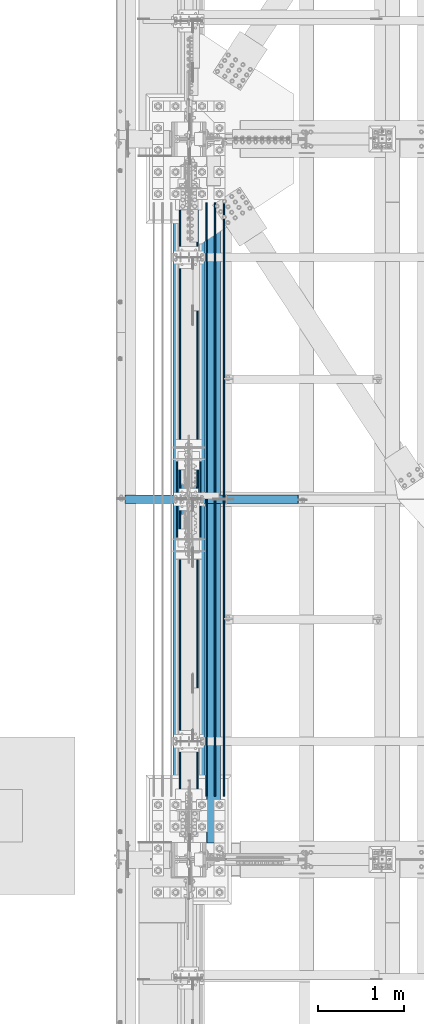
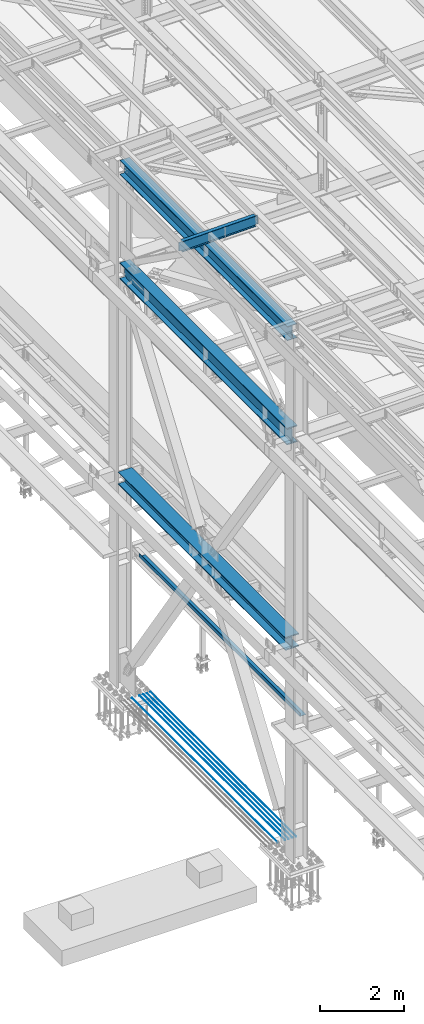
# One storey, part 1813 of 3843: 10 beams, 10 elements without a shape of their own.
"""IFC2X3 building model written with IfcOpenShell, lengths in millimetres."""

from ifc_helpers import new_model, si_unit, frame, origin_with_axes, place, context, subcontext, project, spatial, faceted_brep, material, type_object, element, aggregate, save


model = new_model("IFC2X3")

# Units and contexts
model_context = context("Model", 3, precision=1e-05, world=origin_with_axes())
body_context = subcontext(model_context, "Body", "Model", "MODEL_VIEW")
ifc_project = project(units=[si_unit("LENGTHUNIT", "METRE", prefix="MILLI"), si_unit("AREAUNIT", "SQUARE_METRE"), si_unit("VOLUMEUNIT", "CUBIC_METRE"), si_unit("MASSUNIT", "GRAM", prefix="KILO"), si_unit("TIMEUNIT", "SECOND"), si_unit("PLANEANGLEUNIT", "RADIAN"), si_unit("SOLIDANGLEUNIT", "STERADIAN"), si_unit("THERMODYNAMICTEMPERATUREUNIT", "DEGREE_CELSIUS"), si_unit("LUMINOUSINTENSITYUNIT", "LUMEN")], contexts=[model_context])

# Site, building, storey
site_placement = place(None, origin_with_axes())
site = spatial("IfcSite", under=ifc_project, at=site_placement, CompositionType="ELEMENT")
building_placement = place(site_placement, origin_with_axes())
building = spatial("IfcBuilding", under=site, at=building_placement, Name="Undefined", CompositionType="ELEMENT")
storey_placement = place(building_placement, origin_with_axes())
storey = spatial("IfcBuildingStorey", under=building, at=storey_placement, Name="Undefined", CompositionType="ELEMENT", Elevation=0.0)

# Assembly, beam
assembly_1_placement = place(storey_placement, origin_with_axes())
assembly_1 = element("IfcElementAssembly", 1, at=assembly_1_placement, inside=storey, Name="REBAR", AssemblyPlace="NOTDEFINED", PredefinedType="RIGID_FRAME")
ifc_material_1 = material(Name="STEEL/A706-60")
beam_type_1 = type_object("IfcBeamType", Name="#10 REBAR", PredefinedType="NOTDEFINED")
beam_1_placement = place(assembly_1_placement, frame((36982.4000610352, 51295.3000170885, 30170.4375), z_axis=(0.0, 0.0, 1.0), x_axis=(0.0, 1.0, 0.0)))
beam_1 = element("IfcBeam", 2, at=beam_1_placement, type_object=beam_type_1, material=ifc_material_1, Name="REBAR", ObjectType="#10 REBAR", context=body_context, shape_type="Brep", body=[
    faceted_brep([(0.0, -7.9375, 0.0), (0.0, -5.61266007566883, -5.61266007566883), (6883.48749999408, -5.61266007566883, -5.61266007566883), (6883.48749999408, -7.9375, 0.0), (0.0, 0.0, -7.9375), (6883.48749999408, 0.0, -7.9375), (0.0, 5.61266007566883, -5.61266007566883), (6883.48749999408, 5.61266007566883, -5.61266007566883), (0.0, 7.9375, 0.0), (6883.48749999408, 7.9375, 0.0), (0.0, 5.61266007566883, 5.61266007566883), (6883.48749999408, 5.61266007566883, 5.61266007566883), (0.0, 0.0, 7.9375), (6883.48749999408, 0.0, 7.9375), (0.0, -5.61266007566883, 5.61266007566883), (6883.48749999408, -5.61266007566883, 5.61266007566883)], [[[0, 1, 2, 3]], [[1, 4, 5, 2]], [[4, 6, 7, 5]], [[6, 8, 9, 7]], [[8, 10, 11, 9]], [[10, 12, 13, 11]], [[12, 14, 15, 13]], [[14, 0, 3, 15]], [[5, 7, 9, 11, 13, 15, 3, 2]], [[14, 12, 10, 8, 6, 4, 1, 0]]]),
])
aggregate(assembly_1, [beam_1])

assembly_2_placement = place(storey_placement, origin_with_axes())
assembly_2 = element("IfcElementAssembly", 3, at=assembly_2_placement, inside=storey, Name="REBAR", AssemblyPlace="NOTDEFINED", PredefinedType="RIGID_FRAME")
beam_2_placement = place(assembly_2_placement, frame((36880.8000610352, 51295.3000170885, 30170.4375), z_axis=(0.0, 0.0, 1.0), x_axis=(0.0, 1.0, 0.0)))
beam_2 = element("IfcBeam", 4, at=beam_2_placement, type_object=beam_type_1, material=ifc_material_1, Name="REBAR", ObjectType="#10 REBAR", context=body_context, shape_type="Brep", body=[
    faceted_brep([(0.0, -7.9375, 0.0), (0.0, -5.61266007566883, -5.61266007566883), (6883.48749999408, -5.61266007566883, -5.61266007566883), (6883.48749999408, -7.9375, 0.0), (0.0, 0.0, -7.9375), (6883.48749999408, 0.0, -7.9375), (0.0, 5.61266007566883, -5.61266007566883), (6883.48749999408, 5.61266007566883, -5.61266007566883), (0.0, 7.9375, 0.0), (6883.48749999408, 7.9375, 0.0), (0.0, 5.61266007566883, 5.61266007566883), (6883.48749999408, 5.61266007566883, 5.61266007566883), (0.0, 0.0, 7.9375), (6883.48749999408, 0.0, 7.9375), (0.0, -5.61266007566883, 5.61266007566883), (6883.48749999408, -5.61266007566883, 5.61266007566883)], [[[0, 1, 2, 3]], [[1, 4, 5, 2]], [[4, 6, 7, 5]], [[6, 8, 9, 7]], [[8, 10, 11, 9]], [[10, 12, 13, 11]], [[12, 14, 15, 13]], [[14, 0, 3, 15]], [[5, 7, 9, 11, 13, 15, 3, 2]], [[14, 12, 10, 8, 6, 4, 1, 0]]]),
])
aggregate(assembly_2, [beam_2])

assembly_3_placement = place(storey_placement, origin_with_axes())
assembly_3 = element("IfcElementAssembly", 5, at=assembly_3_placement, inside=storey, Name="REBAR", AssemblyPlace="NOTDEFINED", PredefinedType="RIGID_FRAME")
beam_3_placement = place(assembly_3_placement, frame((36779.2000610352, 51295.3000170885, 30170.4375), z_axis=(0.0, 0.0, 1.0), x_axis=(0.0, 1.0, 0.0)))
beam_3 = element("IfcBeam", 6, at=beam_3_placement, type_object=beam_type_1, material=ifc_material_1, Name="REBAR", ObjectType="#10 REBAR", context=body_context, shape_type="Brep", body=[
    faceted_brep([(0.0, -7.9375, 0.0), (0.0, -5.61266007566883, -5.61266007566883), (6883.48749999408, -5.61266007566883, -5.61266007566883), (6883.48749999408, -7.9375, 0.0), (0.0, 0.0, -7.9375), (6883.48749999408, 0.0, -7.9375), (0.0, 5.61266007566883, -5.61266007566883), (6883.48749999408, 5.61266007566883, -5.61266007566883), (0.0, 7.9375, 0.0), (6883.48749999408, 7.9375, 0.0), (0.0, 5.61266007566883, 5.61266007566883), (6883.48749999408, 5.61266007566883, 5.61266007566883), (0.0, 0.0, 7.9375), (6883.48749999408, 0.0, 7.9375), (0.0, -5.61266007566883, 5.61266007566883), (6883.48749999408, -5.61266007566883, 5.61266007566883)], [[[0, 1, 2, 3]], [[1, 4, 5, 2]], [[4, 6, 7, 5]], [[6, 8, 9, 7]], [[8, 10, 11, 9]], [[10, 12, 13, 11]], [[12, 14, 15, 13]], [[14, 0, 3, 15]], [[5, 7, 9, 11, 13, 15, 3, 2]], [[14, 12, 10, 8, 6, 4, 1, 0]]]),
])
aggregate(assembly_3, [beam_3])

assembly_4_placement = place(storey_placement, origin_with_axes())
assembly_4 = element("IfcElementAssembly", 7, at=assembly_4_placement, inside=storey, Name="REBAR", AssemblyPlace="NOTDEFINED", PredefinedType="RIGID_FRAME")
beam_4_placement = place(assembly_4_placement, frame((36677.6000610352, 51295.3000170885, 30170.4375), z_axis=(0.0, 0.0, 1.0), x_axis=(0.0, 1.0, 0.0)))
beam_4 = element("IfcBeam", 8, at=beam_4_placement, type_object=beam_type_1, material=ifc_material_1, Name="REBAR", ObjectType="#10 REBAR", context=body_context, shape_type="Brep", body=[
    faceted_brep([(0.0, -7.9375, 0.0), (0.0, -5.61266007566883, -5.61266007566883), (6883.48749999408, -5.61266007566883, -5.61266007566883), (6883.48749999408, -7.9375, 0.0), (0.0, 0.0, -7.9375), (6883.48749999408, 0.0, -7.9375), (0.0, 5.61266007566883, -5.61266007566883), (6883.48749999408, 5.61266007566883, -5.61266007566883), (0.0, 7.9375, 0.0), (6883.48749999408, 7.9375, 0.0), (0.0, 5.61266007566883, 5.61266007566883), (6883.48749999408, 5.61266007566883, 5.61266007566883), (0.0, 0.0, 7.9375), (6883.48749999408, 0.0, 7.9375), (0.0, -5.61266007566883, 5.61266007566883), (6883.48749999408, -5.61266007566883, 5.61266007566883)], [[[0, 1, 2, 3]], [[1, 4, 5, 2]], [[4, 6, 7, 5]], [[6, 8, 9, 7]], [[8, 10, 11, 9]], [[10, 12, 13, 11]], [[12, 14, 15, 13]], [[14, 0, 3, 15]], [[5, 7, 9, 11, 13, 15, 3, 2]], [[14, 12, 10, 8, 6, 4, 1, 0]]]),
])
aggregate(assembly_4, [beam_4])

assembly_5_placement = place(storey_placement, origin_with_axes())
assembly_5 = element("IfcElementAssembly", 9, at=assembly_5_placement, inside=storey, Name="REBAR", AssemblyPlace="NOTDEFINED", PredefinedType="RIGID_FRAME")
beam_5_placement = place(assembly_5_placement, frame((36474.4000610352, 51295.3000170885, 30170.4375), z_axis=(0.0, 0.0, 1.0), x_axis=(0.0, 1.0, 0.0)))
beam_5 = element("IfcBeam", 10, at=beam_5_placement, type_object=beam_type_1, material=ifc_material_1, Name="REBAR", ObjectType="#10 REBAR", context=body_context, shape_type="Brep", body=[
    faceted_brep([(0.0, -7.9375, 0.0), (0.0, -5.61266007566883, -5.61266007566883), (6883.48749999408, -5.61266007566883, -5.61266007566883), (6883.48749999408, -7.9375, 0.0), (0.0, 0.0, -7.9375), (6883.48749999408, 0.0, -7.9375), (0.0, 5.61266007566883, -5.61266007566883), (6883.48749999408, 5.61266007566883, -5.61266007566883), (0.0, 7.9375, 0.0), (6883.48749999408, 7.9375, 0.0), (0.0, 5.61266007566883, 5.61266007566883), (6883.48749999408, 5.61266007566883, 5.61266007566883), (0.0, 0.0, 7.9375), (6883.48749999408, 0.0, 7.9375), (0.0, -5.61266007566883, 5.61266007566883), (6883.48749999408, -5.61266007566883, 5.61266007566883)], [[[0, 1, 2, 3]], [[1, 4, 5, 2]], [[4, 6, 7, 5]], [[6, 8, 9, 7]], [[8, 10, 11, 9]], [[10, 12, 13, 11]], [[12, 14, 15, 13]], [[14, 0, 3, 15]], [[5, 7, 9, 11, 13, 15, 3, 2]], [[14, 12, 10, 8, 6, 4, 1, 0]]]),
])
aggregate(assembly_5, [beam_5])

assembly_6_placement = place(storey_placement, origin_with_axes())
assembly_6 = element("IfcElementAssembly", 11, at=assembly_6_placement, inside=storey, Name="BEAM", AssemblyPlace="NOTDEFINED", PredefinedType="RIGID_FRAME")
ifc_material_2 = material(Name="STEEL/A36")
beam_type_2 = type_object("IfcBeamType", PredefinedType="NOTDEFINED")
beam_6_placement = place(assembly_6_placement, frame((36944.3000000007, 54562.375, 34039.175), z_axis=(0.0, -1.0, 0.0), x_axis=(-1.0, 0.0, 0.0)))
beam_6 = element("IfcBeam", 12, at=beam_6_placement, type_object=beam_type_2, material=ifc_material_2, Name="BENT_PLATE", context=body_context, shape_type="Brep", body=[
    faceted_brep([(0.0, -3.17500000000291, -3810.0), (0.0, -3.17500000000291, 3810.0), (0.0, 3.17500000000291, 3810.0), (0.0, 3.17500000000291, -3810.0), (165.100000000697, 3.17500000000291, 3810.0), (165.100000000697, 3.17500000000291, -3810.0), (158.750000000691, -3.17500000000291, -3810.0), (158.750000000691, -3.17500000000291, 3810.0), (165.100000000697, -98.4249999992971, 3810.0), (165.100000000697, -98.4249999992971, -3810.0), (158.750000000691, -98.4249999992971, 3810.0), (158.750000000691, -98.4249999992971, -3810.0)], [[[0, 1, 2, 3]], [[3, 2, 4, 5]], [[1, 0, 6, 7]], [[5, 4, 8, 9]], [[4, 2, 1, 7, 10, 8]], [[7, 6, 11, 10]], [[6, 0, 3, 5, 9, 11]], [[10, 11, 9, 8]]]),
])
aggregate(assembly_6, [beam_6])

assembly_7_placement = place(storey_placement, origin_with_axes())
assembly_7 = element("IfcElementAssembly", 13, at=assembly_7_placement, inside=storey, Name="BEAM", AssemblyPlace="NOTDEFINED", PredefinedType="RIGID_FRAME")
ifc_material_3 = material(Name="STEEL/A992")
beam_type_3 = type_object("IfcBeamType", Name="W12X19", PredefinedType="NOTDEFINED")
beam_7_placement = place(assembly_7_placement, frame((35741.0571586919, 54736.9999999999, 45557.9079249889), z_axis=(-0.0211520980073474, 0.0, 0.999776269347241), x_axis=(0.999776270257024, 0.0, 0.0211520550054619)))
beam_7 = element("IfcBeam", 14, at=beam_7_placement, type_object=beam_type_3, material=ifc_material_3, Name="BEAM", ObjectType="W12X19", context=body_context, shape_type="Brep", body=[
    faceted_brep([(20.6374979119428, -3.17500000000291, -128.587500021946), (20.6374979119428, 3.17500000000291, -128.587500021946), (84.1374979491229, 3.17500000000291, -128.587500085479), (84.1374979491229, -3.17500000000291, -128.587500085479), (88.9975774661289, 3.17500000000291, -129.554230012938), (88.9975774661289, -3.17500000000291, -129.554230012938), (93.1177539315104, 3.17500000000291, -132.307243917545), (93.1177539315104, -3.17500000000291, -132.307243917545), (95.8707678278151, 3.17500000000291, -136.427420388471), (95.8707678278151, -3.17500000000291, -136.427420388471), (96.8374977455387, -3.17500000000291, -141.287499907492), (96.8374977455387, 3.17500000000291, -141.287499907492), (96.8374977423518, 3.17500000000291, -144.462499999776), (96.8374977423518, 50.8000000000029, -144.462499999776), (96.8374977328203, 50.8000000000029, -153.987499999792), (96.8374977328203, -50.8000000000029, -153.987499999792), (96.8374977423518, -50.8000000000029, -144.462499999776), (96.8374977423518, -3.17500000000291, -144.462499999776), (2105.41812082298, 50.8000000000029, 144.462500001886), (2105.41812082298, 3.17500000000291, 144.462500001886), (96.8374980314547, 3.17500000000291, 144.462500000489), (96.8374980314547, 50.8000000000029, 144.462500000489), (84.1374982064444, -3.17500000000291, 128.587499915513), (84.1374982064444, 3.17500000000291, 128.587499915513), (20.637499711811, 3.17500000000291, 128.587499979069), (20.637499711811, -3.17500000000291, 128.587499979069), (88.9975777254003, -3.17500000000291, 129.554229833244), (88.9975777254003, 3.17500000000291, 129.554229833244), (93.1177541962679, -3.17500000000291, 132.307243729607), (93.1177541962679, 3.17500000000291, 132.307243729607), (95.8707681008382, -3.17500000000291, 136.427420195025), (95.8707681008382, 3.17500000000291, 136.427420195025), (96.8374980282824, -3.17500000000291, 141.287499712118), (96.8374980282824, 3.17500000000291, 141.287499712118), (2105.41812082297, -50.8000000000029, 153.987500001873), (2105.41812082297, 50.8000000000029, 153.987500001873), (96.8374980410008, 50.8000000000029, 153.987500000498), (96.8374980410154, -50.8000000000029, 153.987499285155), (2105.41812082298, -50.8000000000029, 144.462500001886), (96.8374980314547, -50.8000000000029, 144.462500000489), (2105.41812082298, -3.17500000000291, 144.462500001886), (96.8374980314547, -3.17500000000291, 144.462500000489), (2105.41812082299, -3.17500000000291, 141.287499819417), (2105.41812082299, 3.17500000000291, 141.287499819417), (2106.38485074557, -3.17500000000291, 136.427420301385), (2106.38485074557, 3.17500000000291, 136.427420301385), (2109.13786464603, -3.17500000000291, 132.307243833253), (2109.13786464603, 3.17500000000291, 132.307243833253), (2113.25804111418, -3.17500000000291, 129.554229932794), (2113.25804111418, 3.17500000000291, 129.554229932794), (2118.11812063219, -3.17500000000291, 128.587500010217), (2118.11812063219, 3.17500000000291, 128.587500010217), (2187.96812082909, -3.17500000000291, 128.58750001029), (2187.96812082909, 3.17500000000291, 128.58750001029), (2187.96812082909, -3.17500000000291, 115.887500021534), (2187.96812082909, -3.17500000000291, -114.712499972484), (2187.96812082909, -3.17500000000291, -128.587499988374), (2187.96812082909, 3.17500000000291, -128.587499988374), (2118.11812063261, -3.17500000000291, -128.58749998844), (2118.11812063261, 3.17500000000291, -128.58749998844), (2113.25804111459, -3.17500000000291, -129.554229911031), (2113.25804111459, 3.17500000000291, -129.554229911031), (2109.13786464647, -3.17500000000291, -132.307243811505), (2109.13786464647, 3.17500000000291, -132.307243811505), (2106.384850746, -3.17500000000291, -136.427420279637), (2106.384850746, 3.17500000000291, -136.427420279637), (2105.41812082342, -3.17500000000291, -141.287499797661), (2105.41812082342, 3.17500000000291, -141.287499797661), (2105.41812082343, -3.17500000000291, -144.462499997644), (2105.41812082343, -50.8000000000029, -144.462499997644), (2105.41812082344, -50.8000000000029, -153.987499997631), (2105.41812082344, 50.8000000000029, -153.987499997631), (2105.41812082343, 50.8000000000029, -144.462499997644), (2105.41812082343, 3.17500000000291, -144.462499997644), (20.6374980090477, 3.17500000000291, -114.712499752241), (20.6374996229279, 3.17500000000291, 115.88750024372)], [[[0, 1, 2, 3]], [[3, 2, 4, 5]], [[5, 4, 6, 7]], [[7, 6, 8, 9]], [[10, 11, 12, 13, 14, 15, 16, 17]], [[9, 8, 11, 10]], [[18, 19, 20, 21]], [[22, 23, 24, 25]], [[26, 27, 23, 22]], [[28, 29, 27, 26]], [[30, 31, 29, 28]], [[32, 33, 31, 30]], [[34, 35, 36, 37]], [[38, 34, 37, 39]], [[40, 38, 39, 41]], [[37, 36, 21, 20, 33, 32, 41, 39]], [[35, 18, 21, 36]], [[34, 38, 40, 42, 43, 19, 18, 35]], [[44, 45, 43, 42]], [[46, 47, 45, 44]], [[48, 49, 47, 46]], [[50, 51, 49, 48]], [[52, 53, 51, 50]], [[53, 52, 54, 55, 56, 57]], [[56, 58, 59, 57]], [[60, 61, 59, 58]], [[62, 63, 61, 60]], [[64, 65, 63, 62]], [[66, 67, 65, 64]], [[68, 69, 70, 71, 72, 73, 67, 66]], [[69, 68, 17, 16]], [[70, 69, 16, 15]], [[71, 70, 15, 14]], [[72, 71, 14, 13]], [[73, 72, 13, 12]], [[6, 4, 2, 1, 74, 75, 24, 23, 27, 29, 31, 33, 20, 19, 43, 45, 47, 49, 51, 53, 57, 59, 61, 63, 65, 67, 73, 12, 11, 8]], [[25, 24, 75, 74, 1, 0]], [[68, 66, 64, 62, 60, 58, 56, 55, 54, 52, 50, 48, 46, 44, 42, 40, 41, 32, 30, 28, 26, 22, 25, 0, 3, 5, 7, 9, 10, 17]]]),
])
aggregate(assembly_7, [beam_7])

assembly_8_placement = place(storey_placement, origin_with_axes())
assembly_8 = element("IfcElementAssembly", 15, at=assembly_8_placement, inside=storey, Name="BEAM", AssemblyPlace="NOTDEFINED", PredefinedType="RIGID_FRAME")
beam_type_4 = type_object("IfcBeamType", Name="W14X120", PredefinedType="NOTDEFINED")
beam_8_placement = place(assembly_8_placement, frame((36576.0, 50558.7, 36252.15), z_axis=(0.0, 0.0, 1.0), x_axis=(0.0, 1.0, 0.0)))
beam_8 = element("IfcBeam", 16, at=beam_8_placement, type_object=beam_type_4, material=ifc_material_3, Name="BEAM", ObjectType="W14X120", context=body_context, shape_type="Brep", body=[
    faceted_brep([(8147.05000000002, -7.14375000001019, 134.9375), (8147.05, -7.14375000000291, 121.389999999999), (8147.05, -7.14375000000291, -121.389999999999), (8147.05000000005, -7.14375000000291, -134.9375), (8138.80110803098, 7.14375000000291, -134.9375), (8138.80110803098, 7.14375000000291, 134.9375), (209.550000000003, 185.737500000003, 160.337500000001), (223.298570425992, 185.737500000003, 184.150000000001), (8133.30142957401, 185.737500000003, 184.150000000001), (8147.05000000005, 185.737500000003, 160.337500000001), (209.550000000003, 7.14375000000291, 160.337500000001), (8147.05000000005, 7.14375000000291, 160.337500000001), (223.298583433396, -185.737500000003, -160.337500000001), (209.550000000003, -185.737500000003, -184.150000000001), (8147.05000000005, -185.737500000003, -184.150000000001), (8133.30141656662, -185.737500000003, -160.337500000001), (209.550000000003, 185.737500000003, -184.150000000001), (8147.05000000005, 185.737500000003, -184.150000000001), (223.298583433396, 185.737500000003, -160.337500000001), (8133.30141656662, 185.737500000003, -160.337500000001), (223.298583433396, 7.14375000000291, -160.337500000001), (8133.30141656662, 7.14375000000291, -160.337500000001), (8092.03473890678, -7.14375000000291, -136.252145122373), (8092.03473890678, 7.14375000000291, -136.252145122373), (8096.86337192042, 7.14375000000291, -134.9375), (8096.86337192042, -7.14375000000291, -134.9375), (8088.53900649017, -7.14375000000291, -139.833184559415), (8088.53900649017, 7.14375000000291, -139.833184559415), (8087.34114007838, -7.14375000000291, -144.692104669659), (8087.34114007838, 7.14375000000291, -144.692104669659), (8088.77179989161, -7.14375000000291, -149.487644376197), (8088.77179989161, 7.14375000000291, -149.487644376197), (8092.43606519062, -7.14375000000291, -152.896038190993), (8092.43606519062, 7.14375000000291, -152.896038190993), (8105.85500000001, -7.14375000000291, -159.940499999997), (8105.85500000001, 7.14375000000291, -159.940499999997), (8133.07220828332, -7.14375000000291, -159.940499999997), (8133.07220828332, 7.14375000000291, -159.940499999997), (8133.30141656662, -7.14375000000291, -160.337500000001), (223.298583433396, -7.14375000000291, -160.337500000001), (223.527791716697, -7.14375000000291, -159.940499999997), (223.527791716697, 7.14375000000291, -159.940499999997), (250.74500000001, -7.14375000000291, -159.940499999997), (250.74500000001, 7.14375000000291, -159.940499999997), (264.163934809403, -7.14375000000291, -152.896038190993), (264.163934809403, 7.14375000000291, -152.896038190993), (267.828200108415, -7.14375000000291, -149.487644376197), (267.828200108415, 7.14375000000291, -149.487644376197), (269.25885992164, -7.14375000000291, -144.692104669659), (269.25885992164, 7.14375000000291, -144.692104669659), (268.060993509847, -7.14375000000291, -139.833184559415), (268.060993509847, 7.14375000000291, -139.833184559415), (264.565261093245, -7.14375000000291, -136.252145122373), (264.565261093245, 7.14375000000291, -136.252145122373), (259.736628079598, -7.14375000000291, -134.9375), (259.736628079598, 7.14375000000291, -134.9375), (209.550000000003, -7.14375000000291, -134.9375), (217.79889196904, 7.14375000000291, -134.9375), (217.79889196904, 7.14374999999563, 134.9375), (209.550000000003, -7.14375000000291, -121.389999999999), (209.550000000003, -7.14375000000291, 121.389999999999), (209.550000000003, -7.14375000000291, 134.9375), (258.229628079585, -7.14375000000291, 134.9375), (258.229628079585, 7.14375000000291, 134.9375), (263.058261093232, -7.14375000000291, 136.252145122373), (263.058261093232, 7.14375000000291, 136.252145122373), (266.55399350985, -7.14375000000291, 139.833184559415), (266.55399350985, 7.14375000000291, 139.833184559415), (267.751859921627, -7.14375000000291, 144.692104669659), (267.751859921627, 7.14375000000291, 144.692104669659), (266.321200108403, -7.14375000000291, 149.487644376204), (266.321200108403, 7.14375000000291, 149.487644376204), (262.656934809391, -7.14375000000291, 152.896038190993), (262.656934809391, 7.14375000000291, 152.896038190993), (249.237999999998, -7.14375000000291, 159.940499999997), (249.237999999998, 7.14375000000291, 159.940499999997), (209.550000000003, -7.14375000000291, 159.940499999997), (209.550000000003, 7.14375000000291, 159.940499999997), (209.550000000003, -7.14375000000291, 160.337500000001), (223.298570425992, -185.737500000003, 184.150000000001), (209.550000000003, -185.737500000003, 160.337500000001), (8147.05000000005, -7.14375000000291, 160.337500000001), (8147.05000000005, -185.737500000003, 160.337500000001), (8133.30142957401, -185.737500000003, 184.150000000001), (8147.05000000005, -7.14375000000291, 159.940499999997), (8147.05000000005, 7.14375000000291, 159.940499999997), (8107.36200000002, -7.14375000000291, 159.940499999997), (8107.36200000002, 7.14375000000291, 159.940499999997), (8093.94306519063, -7.14375000000291, 152.896038190993), (8093.94306519063, 7.14375000000291, 152.896038190993), (8090.27879989162, -7.14375000000291, 149.487644376204), (8090.27879989162, 7.14375000000291, 149.487644376204), (8088.84814007839, -7.14375000000291, 144.692104669659), (8088.84814007839, 7.14375000000291, 144.692104669659), (8090.04600649017, -7.14375000000291, 139.833184559415), (8090.04600649017, 7.14375000000291, 139.833184559415), (8093.54173890679, -7.14375000000291, 136.252145122373), (8093.54173890679, 7.14375000000291, 136.252145122373), (8098.37037192043, -7.14375000000291, 134.9375), (8098.37037192043, 7.14375000000291, 134.9375)], [[[0, 1, 2, 3, 4, 5]], [[6, 7, 8, 9]], [[10, 6, 9, 11]], [[12, 13, 14, 15]], [[13, 16, 17, 14]], [[16, 18, 19, 17]], [[18, 20, 21, 19]], [[22, 23, 24, 25]], [[26, 27, 23, 22]], [[28, 29, 27, 26]], [[30, 31, 29, 28]], [[32, 33, 31, 30]], [[34, 35, 33, 32]], [[35, 34, 36, 37]], [[14, 17, 19, 21, 37, 36, 38, 15]], [[39, 12, 15, 38]], [[40, 41, 20, 18, 16, 13, 12, 39]], [[42, 43, 41, 40]], [[44, 45, 43, 42]], [[46, 47, 45, 44]], [[48, 49, 47, 46]], [[50, 51, 49, 48]], [[52, 53, 51, 50]], [[54, 55, 53, 52]], [[55, 54, 56, 57]], [[58, 57, 56, 59, 60, 61]], [[62, 63, 58, 61]], [[64, 65, 63, 62]], [[66, 67, 65, 64]], [[68, 69, 67, 66]], [[70, 71, 69, 68]], [[72, 73, 71, 70]], [[74, 75, 73, 72]], [[75, 74, 76, 77]], [[77, 76, 78, 10]], [[79, 7, 6, 10, 78, 80]], [[80, 78, 81, 82]], [[79, 80, 82, 83]], [[7, 79, 83, 8]], [[82, 81, 11, 9, 8, 83]], [[84, 85, 11, 81]], [[86, 87, 85, 84]], [[88, 89, 87, 86]], [[90, 91, 89, 88]], [[92, 93, 91, 90]], [[94, 95, 93, 92]], [[96, 97, 95, 94]], [[98, 99, 97, 96]], [[99, 98, 0, 5]], [[24, 23, 27, 29, 31, 33, 35, 37, 21, 20, 41, 43, 45, 47, 49, 51, 53, 55, 57, 58, 63, 65, 67, 69, 71, 73, 75, 77, 10, 11, 85, 87, 89, 91, 93, 95, 97, 99, 5, 4]], [[25, 24, 4, 3]], [[98, 96, 94, 92, 90, 88, 86, 84, 81, 78, 76, 74, 72, 70, 68, 66, 64, 62, 61, 60, 59, 56, 54, 52, 50, 48, 46, 44, 42, 40, 39, 38, 36, 34, 32, 30, 28, 26, 22, 25, 3, 2, 1, 0]]]),
])
aggregate(assembly_8, [beam_8])

assembly_9_placement = place(storey_placement, origin_with_axes())
assembly_9 = element("IfcElementAssembly", 17, at=assembly_9_placement, inside=storey, Name="BEAM", AssemblyPlace="NOTDEFINED", PredefinedType="RIGID_FRAME")
beam_type_5 = type_object("IfcBeamType", Name="W16X67", PredefinedType="NOTDEFINED")
beam_9_placement = place(assembly_9_placement, frame((36576.0000000347, 50558.7, 45210.4125000004), z_axis=(0.0, 0.0, 1.0), x_axis=(0.0, 1.0, 0.0)))
beam_9 = element("IfcBeam", 18, at=beam_9_placement, type_object=beam_type_5, material=ifc_material_3, Name="BEAM", ObjectType="W16X67", context=body_context, shape_type="Brep", body=[
    faceted_brep([(212.724999999991, -130.175000000003, -207.962500000001), (212.724999999991, 130.175000000003, -207.962500000001), (8143.87500000003, 130.175000000003, -207.962500000001), (8143.87500000003, -130.175000000003, -207.962500000001), (212.724999999991, -130.175000000003, -190.5), (212.724999999991, -4.76249999999709, -190.5), (212.724999999991, -4.76249999999709, -142.027500000993), (212.724999999991, -4.76249999999709, 176.952499999003), (212.724999999991, -4.76249999999709, 190.5), (212.724999999991, -130.175000000003, 190.5), (212.724999999991, -130.175000000003, 207.962500000001), (212.724999999991, 130.175000000003, 207.962500000001), (212.724999999991, 130.175000000003, 190.5), (212.724999999991, 4.76249999999709, 190.5), (212.724999999991, 4.76249999999709, -190.5), (212.724999999991, 130.175000000003, -190.5), (8143.87500000003, -130.175000000003, -190.5), (8143.87500000003, -4.76249999999709, -190.5), (8143.87500000003, -4.76249999999709, -142.02750001238), (8143.87500000003, -4.76249999999709, 176.952499987616), (8143.87500000003, -4.76249999999709, 190.5), (8143.87500000003, -130.175000000003, 190.5), (8143.87500000003, -130.175000000003, 207.962500000001), (8143.87500000003, 130.175000000003, 207.962500000001), (8143.87500000003, 130.175000000003, 190.5), (8143.87500000003, 4.76249999999709, 190.5), (8143.87500000003, 4.76249999999709, -190.5), (8143.87500000003, 130.175000000003, -190.5)], [[[0, 1, 2, 3]], [[0, 4, 5, 6, 7, 8, 9, 10, 11, 12, 13, 14, 15, 1]], [[5, 4, 16, 17]], [[8, 7, 6, 5, 17, 18, 19, 20]], [[9, 8, 20, 21]], [[10, 9, 21, 22]], [[11, 10, 22, 23]], [[12, 11, 23, 24]], [[13, 12, 24, 25]], [[14, 13, 25, 26]], [[15, 14, 26, 27]], [[1, 15, 27, 2]], [[26, 25, 24, 23, 22, 21, 20, 19, 18, 17, 16, 3, 2, 27]], [[4, 0, 3, 16]]]),
])
aggregate(assembly_9, [beam_9])

assembly_10_placement = place(storey_placement, origin_with_axes())
assembly_10 = element("IfcElementAssembly", 19, at=assembly_10_placement, inside=storey, Name="BEAM", AssemblyPlace="NOTDEFINED", PredefinedType="RIGID_FRAME")
beam_type_6 = type_object("IfcBeamType", Name="W18X97", PredefinedType="NOTDEFINED")
beam_10_placement = place(assembly_10_placement, frame((36576.000000019, 50558.7, 42232.2625), z_axis=(0.0, 0.0, 1.0), x_axis=(0.0, 1.0, 0.0)))
beam_10 = element("IfcBeam", 20, at=beam_10_placement, type_object=beam_type_6, material=ifc_material_3, Name="BEAM", ObjectType="W18X97", context=body_context, shape_type="Brep", body=[
    faceted_brep([(217.79889196912, 7.14375000024302, 179.387499999997), (217.79889196912, 7.14375000000291, -179.387499999997), (209.550000000003, -7.14375000000291, -179.387499999997), (209.550000000003, -7.14375000000291, 179.387499999997), (287.27926558147, -7.14375000000291, -179.387499999997), (287.27926558147, 7.14375000000291, -179.387499999997), (292.342430772223, 7.14375000000291, -180.844663726282), (292.342430772223, -7.14375000000291, -180.844663726282), (295.856438807779, 7.14375000000291, -184.770312131339), (295.856438807779, -7.14375000000291, -184.770312131339), (296.74612218191, 7.14375000000291, -189.963329690319), (296.74612218191, -7.14375000000291, -189.963329690319), (294.739267898804, 7.14375000000291, -194.834828818966), (294.739267898804, -7.14375000000291, -194.834828818966), (290.449905435082, 7.14375000000291, -197.89429568901), (290.449905435082, -7.14375000000291, -197.89429568901), (245.065000000002, 7.14375000000291, -213.915500000003), (245.065000000002, -7.14375000000291, -213.915500000003), (222.610799311304, 7.14375000000291, -213.915500000003), (222.610799311304, -7.14375000000291, -213.915500000003), (222.381598622604, 7.14375000000291, -214.3125), (222.381598622604, 141.287499999999, -214.3125), (209.550000000003, 141.287499999999, -236.537499999999), (209.550000000003, -141.287499999999, -236.537499999999), (222.381598622604, -141.287499999999, -214.3125), (222.381598622604, -7.14375000000291, -214.3125), (8134.21840137741, 7.14375000000291, -214.3125), (8134.21840137741, 141.287499999999, -214.3125), (8147.05000000001, 141.287499999999, -236.537499999999), (8147.05000000001, -141.287499999999, -236.537499999999), (8134.21840137741, -141.287499999999, -214.3125), (8134.21840137741, -7.14375000000291, -214.3125), (8133.98920068871, 7.14375000000291, -213.915500000003), (8133.98920068871, -7.14375000000291, -213.915500000003), (8111.53500000001, 7.14375000000291, -213.915500000003), (8111.53500000001, -7.14375000000291, -213.915500000003), (8066.15009456493, 7.14375000000291, -197.89429568901), (8066.15009456493, -7.14375000000291, -197.89429568901), (8061.86073210121, 7.14375000000291, -194.834828818966), (8061.86073210121, -7.14375000000291, -194.834828818966), (8059.8538778181, 7.14375000000291, -189.963329690319), (8059.8538778181, -7.14375000000291, -189.963329690319), (8060.74356119224, 7.14375000000291, -184.770312131339), (8060.74356119224, -7.14375000000291, -184.770312131339), (8064.25756922779, 7.14375000000291, -180.844663726282), (8064.25756922779, -7.14375000000291, -180.844663726282), (8069.32073441854, 7.14375000000291, -179.387499999997), (8069.32073441854, -7.14375000000291, -179.387499999997), (8138.80110803089, 7.14375000000291, -179.387499999997), (8147.05000000001, -7.14375000000291, -179.387499999997), (8147.05000000001, -7.14375000000291, 179.387499999997), (8138.80110803089, 7.14375000000291, 179.387499999997), (8069.91073441855, 7.14375000000291, 179.387499999997), (8069.91073441855, -7.14375000000291, 179.387499999997), (8064.84756922779, 7.14375000000291, 180.844663726282), (8064.84756922779, -7.14375000000291, 180.844663726282), (8061.33356119224, 7.14375000000291, 184.770312131339), (8061.33356119224, -7.14375000000291, 184.770312131339), (8060.44387781811, 7.14375000000291, 189.963329690319), (8060.44387781811, -7.14375000000291, 189.963329690319), (8062.45073210121, 7.14375000000291, 194.834828818966), (8062.45073210121, -7.14375000000291, 194.834828818966), (8066.74009456494, 7.14375000000291, 197.89429568901), (8066.74009456494, -7.14375000000291, 197.89429568901), (8112.12500000001, 7.14375000000291, 213.915500000003), (8112.12500000001, -7.14375000000291, 213.915500000003), (8147.05000000001, 7.14375000000291, 213.915500000003), (8147.05000000001, -7.14375000000291, 213.915500000003), (8147.05000000001, 7.14375000000291, 214.3125), (8147.05000000001, -7.14375000000291, 214.3125), (209.550000000003, 7.14375000000291, 214.3125), (209.550000000003, 141.287499999999, 214.3125), (8147.05000000001, 141.287499999999, 214.3125), (222.381584748073, 141.287499999999, 236.537499999999), (8134.21841525194, 141.287499999999, 236.537499999999), (222.381584748073, -141.287499999999, 236.537499999999), (209.550000000003, -141.287499999999, 214.3125), (8147.05000000001, -141.287499999999, 214.3125), (8134.21841525194, -141.287499999999, 236.537499999999), (209.550000000003, -7.14375000000291, 214.3125), (209.550000000003, 7.14375000000291, 213.915500000003), (209.550000000003, -7.14375000000291, 213.915500000003), (244.474999999999, 7.14375000000291, 213.915500000003), (244.474999999999, -7.14375000000291, 213.915500000003), (289.859905435078, 7.14375000000291, 197.89429568901), (289.859905435078, -7.14375000000291, 197.89429568901), (294.1492678988, 7.14375000000291, 194.834828818966), (294.1492678988, -7.14375000000291, 194.834828818966), (296.156122181907, 7.14375000000291, 189.963329690319), (296.156122181907, -7.14375000000291, 189.963329690319), (295.266438807776, 7.14375000000291, 184.770312131339), (295.266438807776, -7.14375000000291, 184.770312131339), (291.75243077222, 7.14375000000291, 180.844663726282), (291.75243077222, -7.14375000000291, 180.844663726282), (286.689265581466, 7.14375000000291, 179.387499999997), (286.689265581466, -7.14375000000291, 179.387499999997)], [[[0, 1, 2, 3]], [[4, 5, 6, 7]], [[7, 6, 8, 9]], [[9, 8, 10, 11]], [[11, 10, 12, 13]], [[13, 12, 14, 15]], [[15, 14, 16, 17]], [[17, 16, 18, 19]], [[19, 18, 20, 21, 22, 23, 24, 25]], [[21, 20, 26, 27]], [[22, 21, 27, 28]], [[23, 22, 28, 29]], [[24, 23, 29, 30]], [[25, 24, 30, 31]], [[29, 28, 27, 26, 32, 33, 31, 30]], [[34, 35, 33, 32]], [[35, 34, 36, 37]], [[37, 36, 38, 39]], [[39, 38, 40, 41]], [[41, 40, 42, 43]], [[43, 42, 44, 45]], [[45, 44, 46, 47]], [[47, 46, 48, 49]], [[50, 49, 48, 51]], [[52, 53, 50, 51]], [[53, 52, 54, 55]], [[55, 54, 56, 57]], [[57, 56, 58, 59]], [[59, 58, 60, 61]], [[61, 60, 62, 63]], [[63, 62, 64, 65]], [[65, 64, 66, 67]], [[67, 66, 68, 69]], [[70, 71, 72, 68]], [[71, 73, 74, 72]], [[75, 76, 77, 78]], [[73, 75, 78, 74]], [[77, 69, 68, 72, 74, 78]], [[76, 79, 69, 77]], [[75, 73, 71, 70, 79, 76]], [[80, 81, 79, 70]], [[82, 83, 81, 80]], [[83, 82, 84, 85]], [[85, 84, 86, 87]], [[87, 86, 88, 89]], [[89, 88, 90, 91]], [[91, 90, 92, 93]], [[93, 92, 94, 95]], [[95, 94, 0, 3]], [[4, 7, 9, 11, 13, 15, 17, 19, 25, 31, 33, 35, 37, 39, 41, 43, 45, 47, 49, 50, 53, 55, 57, 59, 61, 63, 65, 67, 69, 79, 81, 83, 85, 87, 89, 91, 93, 95, 3, 2]], [[5, 4, 2, 1]], [[94, 92, 90, 88, 86, 84, 82, 80, 70, 68, 66, 64, 62, 60, 58, 56, 54, 52, 51, 48, 46, 44, 42, 40, 38, 36, 34, 32, 26, 20, 18, 16, 14, 12, 10, 8, 6, 5, 1, 0]]]),
])
aggregate(assembly_10, [beam_10])

save(model, "model.ifc")
